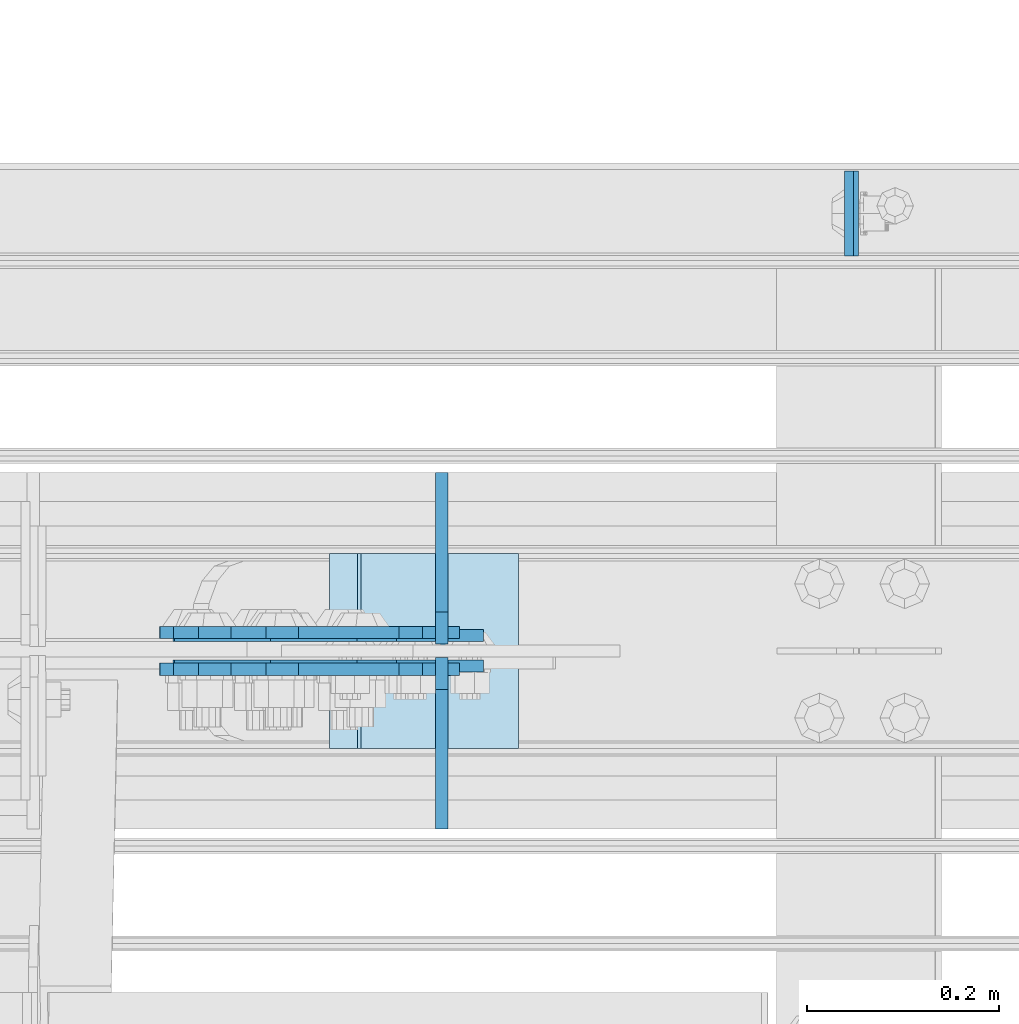
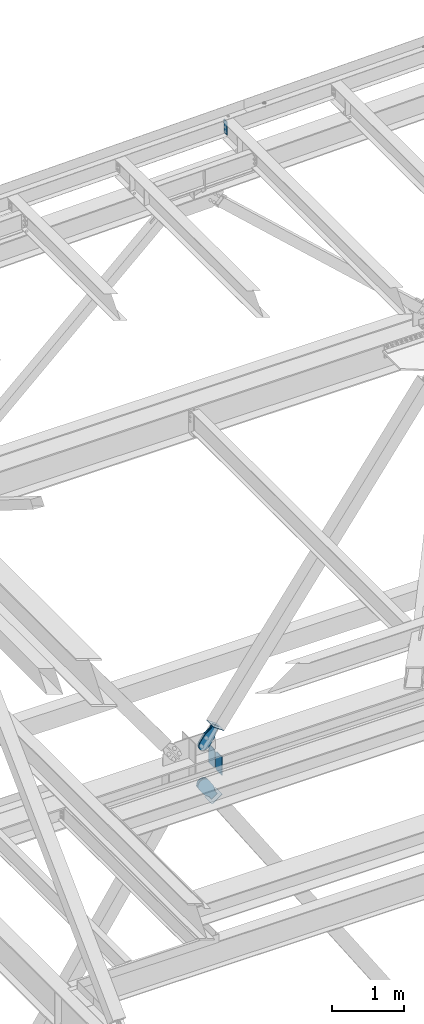
# One storey, part 3649 of 3843: 9 plates, 8 elements without a shape of their own.
"""IFC2X3 building model written with IfcOpenShell, lengths in millimetres."""

from ifc_helpers import new_model, si_unit, frame, origin_with_axes, place, context, subcontext, project, spatial, faceted_brep, material, type_object, element, aggregate, save


model = new_model("IFC2X3")

# Units and contexts
model_context = context("Model", 3, precision=1e-05, world=origin_with_axes())
body_context = subcontext(model_context, "Body", "Model", "MODEL_VIEW")
ifc_project = project(units=[si_unit("LENGTHUNIT", "METRE", prefix="MILLI"), si_unit("AREAUNIT", "SQUARE_METRE"), si_unit("VOLUMEUNIT", "CUBIC_METRE"), si_unit("MASSUNIT", "GRAM", prefix="KILO"), si_unit("TIMEUNIT", "SECOND"), si_unit("PLANEANGLEUNIT", "RADIAN"), si_unit("SOLIDANGLEUNIT", "STERADIAN"), si_unit("THERMODYNAMICTEMPERATUREUNIT", "DEGREE_CELSIUS"), si_unit("LUMINOUSINTENSITYUNIT", "LUMEN")], contexts=[model_context])

# Site, building, storey
site_placement = place(None, origin_with_axes())
site = spatial("IfcSite", under=ifc_project, at=site_placement, CompositionType="ELEMENT")
building_placement = place(site_placement, origin_with_axes())
building = spatial("IfcBuilding", under=site, at=building_placement, Name="Undefined", CompositionType="ELEMENT")
storey_placement = place(building_placement, origin_with_axes())
storey = spatial("IfcBuildingStorey", under=building, at=storey_placement, Name="Undefined", CompositionType="ELEMENT", Elevation=0.0)

# Assembly, plate
assembly_1_placement = place(storey_placement, origin_with_axes())
assembly_1 = element("IfcElementAssembly", 1, at=assembly_1_placement, inside=storey, Name="CHANNEL", AssemblyPlace="NOTDEFINED", PredefinedType="RIGID_FRAME")
ifc_material_1 = material(Name="STEEL/A572-50")
plate_type_1 = type_object("IfcPlateType", PredefinedType="NOTDEFINED")
plate_1_placement = place(assembly_1_placement, frame((82180.6886955897, 105059.162500026, 46656.3368329081), z_axis=(0.0, -1.0, 0.0), x_axis=(0.0211520550054438, 0.0, -0.999776270257025)))
plate_1 = element("IfcPlate", 2, at=plate_1_placement, type_object=plate_type_1, material=ifc_material_1, Name="PLATE", context=body_context, shape_type="Brep", body=[
    faceted_brep([(0.0, -4.76249999999709, 0.0), (0.0, -4.76249999999709, 88.9000015258789), (0.0, 4.76249999999709, 88.9000015258789), (0.0, 4.76249999999709, 0.0), (228.600006102781, -4.7625000004191, 88.9000015257589), (228.600006102781, 4.76249999954598, 88.9000015257443), (228.600006103079, -4.7625000004482, 7.27595761418343e-12), (228.600006103079, 4.76249999954598, -7.27595761418343e-12)], [[[0, 1, 2, 3]], [[1, 4, 5, 2]], [[4, 6, 7, 5]], [[6, 0, 3, 7]], [[5, 7, 3, 2]], [[6, 4, 1, 0]]]),
])
aggregate(assembly_1, [plate_1])

# Assembly, plates
assembly_2_placement = place(storey_placement, origin_with_axes())
assembly_2 = element("IfcElementAssembly", 3, at=assembly_2_placement, inside=storey, Name="BEAM", AssemblyPlace="NOTDEFINED", PredefinedType="RIGID_FRAME")
plate_type_2 = type_object("IfcPlateType", PredefinedType="NOTDEFINED")
plate_2_placement = place(assembly_2_placement, frame((81756.2703202162, 104566.24375, 36093.4), z_axis=(0.0, 1.0, 0.0), x_axis=(0.0, 0.0, 1.0)))
plate_2 = element("IfcPlate", 4, at=plate_2_placement, type_object=plate_type_2, material=ifc_material_1, Name="CB_BEAM", context=body_context, shape_type="Brep", body=[
    faceted_brep([(0.0, -6.34999999999854, 33.3375015258789), (0.0, -6.34999999999854, 178.59375), (0.0, 6.34999999999854, 178.59375), (0.0, 6.34999999999854, 33.3375015258789), (317.499999999985, -6.34999999999854, 178.59375), (317.499999999985, 6.34999999999854, 178.59375), (317.499999999985, -6.34999999999854, 33.3375015258789), (317.499999999985, 6.34999999999854, 33.3375015258789), (284.162498474107, -6.34999999999854, 0.0), (284.162498474107, 6.34999999999854, 0.0), (33.3375015258789, -6.34999999999854, 0.0), (33.3375015258789, 6.34999999999854, 0.0)], [[[0, 1, 2, 3]], [[1, 4, 5, 2]], [[4, 6, 7, 5]], [[6, 8, 9, 7]], [[8, 10, 11, 9]], [[10, 0, 3, 11]], [[5, 7, 9, 11, 3, 2]], [[10, 8, 6, 4, 1, 0]]]),
])
plate_3_placement = place(assembly_2_placement, frame((81756.2703202162, 104551.95625, 36093.4), z_axis=(0.0, -1.0, 0.0), x_axis=(0.0, 0.0, 1.0)))
plate_3 = element("IfcPlate", 5, at=plate_3_placement, type_object=plate_type_2, material=ifc_material_1, Name="CB_BEAM", context=body_context, shape_type="Brep", body=[
    faceted_brep([(0.0, -6.34999999999854, 33.3375015258789), (0.0, -6.34999999999854, 178.59375), (0.0, 6.34999999999854, 178.59375), (0.0, 6.34999999999854, 33.3375015258789), (317.499999999985, -6.34999999999854, 178.59375), (317.499999999985, 6.34999999999854, 178.59375), (317.499999999985, -6.34999999999854, 33.3375015258789), (317.499999999985, 6.34999999999854, 33.3375015258789), (284.162498474107, -6.34999999999854, 0.0), (284.162498474107, 6.34999999999854, 0.0), (33.3375015258789, -6.34999999999854, 0.0), (33.3375015258789, 6.34999999999854, 0.0)], [[[0, 1, 2, 3]], [[1, 4, 5, 2]], [[4, 6, 7, 5]], [[6, 8, 9, 7]], [[8, 10, 11, 9]], [[10, 0, 3, 11]], [[5, 7, 9, 11, 3, 2]], [[10, 8, 6, 4, 1, 0]]]),
])
aggregate(assembly_2, [plate_2, plate_3])

# Assembly, plate
assembly_3_placement = place(storey_placement, origin_with_axes())
assembly_3 = element("IfcElementAssembly", 6, at=assembly_3_placement, inside=storey, Name="Plate", AssemblyPlace="NOTDEFINED", PredefinedType="RIGID_FRAME")
ifc_material_2 = material(Name="STEEL/A36")
plate_type_3 = type_object("IfcPlateType", PredefinedType="NOTDEFINED")
plate_4_placement = place(assembly_3_placement, frame((81834.6793505776, 104457.5, 36773.0205801808), z_axis=(-0.809109618324204, 0.0, 0.58765774523549), x_axis=(0.0, 1.0, 0.0)))
plate_4 = element("IfcPlate", 7, at=plate_4_placement, type_object=plate_type_3, material=ifc_material_2, Name="Plate", context=body_context, shape_type="Brep", body=[
    faceted_brep([(0.0, -3.17499999999927, 0.0), (0.0, -3.17500000043947, 203.200000001736), (0.0, 3.1749999995518, 203.200000001743), (0.0, 3.17499999999927, 0.0), (203.200000000012, -3.17500000043947, 203.200000001736), (203.200000000012, 3.1749999995518, 203.200000001743), (203.199996948242, -3.17499999999927, 0.0), (203.199996948242, 3.17499999999927, 0.0)], [[[0, 1, 2, 3]], [[1, 4, 5, 2]], [[4, 6, 7, 5]], [[6, 0, 3, 7]], [[5, 7, 3, 2]], [[6, 4, 1, 0]]]),
])
aggregate(assembly_3, [plate_4])

assembly_4_placement = place(storey_placement, origin_with_axes())
assembly_4 = element("IfcElementAssembly", 8, at=assembly_4_placement, inside=storey, Name="Plate", AssemblyPlace="NOTDEFINED", PredefinedType="RIGID_FRAME")
plate_5_placement = place(assembly_4_placement, frame((81641.2596382379, 104660.7, 35595.7440063766), z_axis=(0.835270498690033, 0.0, 0.549839243795951), x_axis=(0.0, -1.0, 0.0)))
plate_5 = element("IfcPlate", 9, at=plate_5_placement, type_object=plate_type_3, material=ifc_material_2, Name="Plate", context=body_context, shape_type="Brep", body=[
    faceted_brep([(0.0, -3.17499999999927, 0.0), (0.0, -3.17500000043947, 203.200000001736), (0.0, 3.1749999995518, 203.200000001743), (0.0, 3.17499999999927, 0.0), (203.200000000012, -3.17500000043947, 203.200000001736), (203.200000000012, 3.1749999995518, 203.200000001743), (203.199996948242, -3.17499999999927, 0.0), (203.199996948242, 3.17499999999927, 0.0)], [[[0, 1, 2, 3]], [[1, 4, 5, 2]], [[4, 6, 7, 5]], [[6, 0, 3, 7]], [[5, 7, 3, 2]], [[6, 4, 1, 0]]]),
])
aggregate(assembly_4, [plate_5])

assembly_5_placement = place(storey_placement, origin_with_axes())
assembly_5 = element("IfcElementAssembly", 10, at=assembly_5_placement, inside=storey, AssemblyPlace="NOTDEFINED", PredefinedType="RIGID_FRAME")
plate_type_4 = type_object("IfcPlateType", PredefinedType="NOTDEFINED")
plate_6_placement = place(assembly_5_placement, frame((81758.6766864523, 104574.975, 36745.8160515626), z_axis=(-0.809109618324204, 0.0, 0.58765774523549), x_axis=(0.587657745235489, 0.0, 0.809109618324206)))
plate_6 = element("IfcPlate", 11, at=plate_6_placement, type_object=plate_type_4, material=ifc_material_2, context=body_context, shape_type="Brep", body=[
    faceted_brep([(0.0, -6.3499999046162, 0.0), (-101.600000000049, -6.35000000000582, -37.5700346004523), (-101.600000000049, 6.35000000000582, -37.5700346004523), (7.27595761418343e-12, 6.3499999046162, 0.0), (-245.369242325265, -6.35000000000582, -37.5700346003141), (-245.369242325265, 6.35000000000582, -37.5700346003141), (-281.212328726207, -6.35000000000582, -30.4404014297979), (-281.212328726207, 6.35000000000582, -30.4404014297979), (-311.59863014071, -6.35000000000582, -10.1369239383566), (-311.59863014071, 6.35000000000582, -10.1369239383566), (-331.902107630653, -6.35000000000582, 20.2493774772229), (-331.902107630653, 6.35000000000582, 20.2493774772229), (-339.031740799503, -6.35000000000582, 56.0924669294036), (-339.031740799503, 6.35000000000582, 56.0924669294036), (-331.902107628353, -6.35000000000582, 91.9355533280759), (-331.902107628353, 6.35000000000582, 91.9355533280759), (-311.598630138033, -6.35000000000582, 122.321854740563), (-311.598630138033, 6.35000000000582, 122.321854740563), (-281.212328724767, -6.35000000000582, 142.625332229603), (-281.212328724767, 6.35000000000582, 142.625332229603), (-245.369240796863, -6.35000000000582, 149.754965399145), (-245.369240796863, 6.35000000000582, 149.754965399145), (-101.599999991755, -6.35000000000582, 149.754965398992), (-101.599999991755, 6.35000000000582, 149.754965398992), (4.9622030928731e-09, -6.35000000000582, 112.184930798256), (4.9622030928731e-09, 6.35000000000582, 112.184930798256), (69.8500000038475, -6.35000000000582, 112.184930798168), (69.8500000038475, 6.35000000000582, 112.184930798168), (69.8499999985434, -6.35000000000582, -8.73114913702011e-11), (69.8499999985434, 6.35000000000582, -8.73114913702011e-11)], [[[0, 1, 2, 3]], [[1, 4, 5, 2]], [[4, 6, 7, 5]], [[6, 8, 9, 7]], [[8, 10, 11, 9]], [[10, 12, 13, 11]], [[12, 14, 15, 13]], [[14, 16, 17, 15]], [[16, 18, 19, 17]], [[18, 20, 21, 19]], [[20, 22, 23, 21]], [[22, 24, 25, 23]], [[24, 26, 27, 25]], [[26, 28, 29, 27]], [[28, 0, 3, 29]], [[5, 7, 9, 11, 13, 15, 17, 19, 21, 23, 25, 27, 29, 3, 2]], [[28, 26, 24, 22, 20, 18, 16, 14, 12, 10, 8, 6, 4, 1, 0]]]),
])
aggregate(assembly_5, [plate_6])

assembly_6_placement = place(storey_placement, origin_with_axes())
assembly_6 = element("IfcElementAssembly", 12, at=assembly_6_placement, inside=storey, AssemblyPlace="NOTDEFINED", PredefinedType="RIGID_FRAME")
plate_7_placement = place(assembly_6_placement, frame((81758.6766864523, 104543.225, 36745.8160515626), z_axis=(-0.809109618324204, 0.0, 0.58765774523549), x_axis=(0.587657745235489, 0.0, 0.809109618324206)))
plate_7 = element("IfcPlate", 13, at=plate_7_placement, type_object=plate_type_4, material=ifc_material_2, context=body_context, shape_type="Brep", body=[
    faceted_brep([(0.0, -6.3499999046162, 0.0), (-101.600000000049, -6.35000000000582, -37.5700346004523), (-101.600000000049, 6.35000000000582, -37.5700346004523), (7.27595761418343e-12, 6.3499999046162, 0.0), (-245.369242325265, -6.35000000000582, -37.5700346003141), (-245.369242325265, 6.35000000000582, -37.5700346003141), (-281.212328726207, -6.35000000000582, -30.4404014297979), (-281.212328726207, 6.35000000000582, -30.4404014297979), (-311.59863014071, -6.35000000000582, -10.1369239383566), (-311.59863014071, 6.35000000000582, -10.1369239383566), (-331.902107630653, -6.35000000000582, 20.2493774772229), (-331.902107630653, 6.35000000000582, 20.2493774772229), (-339.031740799503, -6.35000000000582, 56.0924669294036), (-339.031740799503, 6.35000000000582, 56.0924669294036), (-331.902107628353, -6.35000000000582, 91.9355533280759), (-331.902107628353, 6.35000000000582, 91.9355533280759), (-311.598630138033, -6.35000000000582, 122.321854740563), (-311.598630138033, 6.35000000000582, 122.321854740563), (-281.212328724767, -6.35000000000582, 142.625332229603), (-281.212328724767, 6.35000000000582, 142.625332229603), (-245.369240796863, -6.35000000000582, 149.754965399145), (-245.369240796863, 6.35000000000582, 149.754965399145), (-101.599999991755, -6.35000000000582, 149.754965398992), (-101.599999991755, 6.35000000000582, 149.754965398992), (4.9622030928731e-09, -6.35000000000582, 112.184930798256), (4.9622030928731e-09, 6.35000000000582, 112.184930798256), (69.8500000038475, -6.35000000000582, 112.184930798168), (69.8500000038475, 6.35000000000582, 112.184930798168), (69.8499999985434, -6.35000000000582, -8.73114913702011e-11), (69.8499999985434, 6.35000000000582, -8.73114913702011e-11)], [[[0, 1, 2, 3]], [[1, 4, 5, 2]], [[4, 6, 7, 5]], [[6, 8, 9, 7]], [[8, 10, 11, 9]], [[10, 12, 13, 11]], [[12, 14, 15, 13]], [[14, 16, 17, 15]], [[16, 18, 19, 17]], [[18, 20, 21, 19]], [[20, 22, 23, 21]], [[22, 24, 25, 23]], [[24, 26, 27, 25]], [[26, 28, 29, 27]], [[28, 0, 3, 29]], [[5, 7, 9, 11, 13, 15, 17, 19, 21, 23, 25, 27, 29, 3, 2]], [[28, 26, 24, 22, 20, 18, 16, 14, 12, 10, 8, 6, 4, 1, 0]]]),
])
aggregate(assembly_6, [plate_7])

assembly_7_placement = place(storey_placement, origin_with_axes())
assembly_7 = element("IfcElementAssembly", 14, at=assembly_7_placement, inside=storey, AssemblyPlace="NOTDEFINED", PredefinedType="RIGID_FRAME")
plate_8_placement = place(assembly_7_placement, frame((81736.314970746, 104578.15, 35738.1411727646), z_axis=(-0.835270498690038, 0.0, -0.549839243795943), x_axis=(0.549839243795943, 0.0, -0.835270498690039)))
plate_8 = element("IfcPlate", 15, at=plate_8_placement, type_object=plate_type_4, material=ifc_material_2, context=body_context, shape_type="Brep", body=[
    faceted_brep([(0.0, -6.3499999046162, 0.0), (-101.600000000049, -6.35000000000582, -37.5700346004523), (-101.600000000049, 6.35000000000582, -37.5700346004523), (7.27595761418343e-12, 6.3499999046162, 0.0), (-245.369242325265, -6.35000000000582, -37.5700346003141), (-245.369242325265, 6.35000000000582, -37.5700346003141), (-281.212328726207, -6.35000000000582, -30.4404014297979), (-281.212328726207, 6.35000000000582, -30.4404014297979), (-311.59863014071, -6.35000000000582, -10.1369239383566), (-311.59863014071, 6.35000000000582, -10.1369239383566), (-331.902107630653, -6.35000000000582, 20.2493774772229), (-331.902107630653, 6.35000000000582, 20.2493774772229), (-339.031740799503, -6.35000000000582, 56.0924669294036), (-339.031740799503, 6.35000000000582, 56.0924669294036), (-331.902107628353, -6.35000000000582, 91.9355533280759), (-331.902107628353, 6.35000000000582, 91.9355533280759), (-311.598630138033, -6.35000000000582, 122.321854740563), (-311.598630138033, 6.35000000000582, 122.321854740563), (-281.212328724767, -6.35000000000582, 142.625332229603), (-281.212328724767, 6.35000000000582, 142.625332229603), (-245.369240796863, -6.35000000000582, 149.754965399145), (-245.369240796863, 6.35000000000582, 149.754965399145), (-101.599999991755, -6.35000000000582, 149.754965398992), (-101.599999991755, 6.35000000000582, 149.754965398992), (4.9622030928731e-09, -6.35000000000582, 112.184930798256), (4.9622030928731e-09, 6.35000000000582, 112.184930798256), (69.8500000038475, -6.35000000000582, 112.184930798168), (69.8500000038475, 6.35000000000582, 112.184930798168), (69.8499999985434, -6.35000000000582, -8.73114913702011e-11), (69.8499999985434, 6.35000000000582, -8.73114913702011e-11)], [[[0, 1, 2, 3]], [[1, 4, 5, 2]], [[4, 6, 7, 5]], [[6, 8, 9, 7]], [[8, 10, 11, 9]], [[10, 12, 13, 11]], [[12, 14, 15, 13]], [[14, 16, 17, 15]], [[16, 18, 19, 17]], [[18, 20, 21, 19]], [[20, 22, 23, 21]], [[22, 24, 25, 23]], [[24, 26, 27, 25]], [[26, 28, 29, 27]], [[28, 0, 3, 29]], [[5, 7, 9, 11, 13, 15, 17, 19, 21, 23, 25, 27, 29, 3, 2]], [[28, 26, 24, 22, 20, 18, 16, 14, 12, 10, 8, 6, 4, 1, 0]]]),
])
aggregate(assembly_7, [plate_8])

assembly_8_placement = place(storey_placement, origin_with_axes())
assembly_8 = element("IfcElementAssembly", 16, at=assembly_8_placement, inside=storey, AssemblyPlace="NOTDEFINED", PredefinedType="RIGID_FRAME")
plate_9_placement = place(assembly_8_placement, frame((81736.314970746, 104540.05, 35738.1411727646), z_axis=(-0.835270498690038, 0.0, -0.549839243795943), x_axis=(0.549839243795943, 0.0, -0.835270498690039)))
plate_9 = element("IfcPlate", 17, at=plate_9_placement, type_object=plate_type_4, material=ifc_material_2, context=body_context, shape_type="Brep", body=[
    faceted_brep([(0.0, -6.3499999046162, 0.0), (-101.600000000049, -6.35000000000582, -37.5700346004523), (-101.600000000049, 6.35000000000582, -37.5700346004523), (7.27595761418343e-12, 6.3499999046162, 0.0), (-245.369242325265, -6.35000000000582, -37.5700346003141), (-245.369242325265, 6.35000000000582, -37.5700346003141), (-281.212328726207, -6.35000000000582, -30.4404014297979), (-281.212328726207, 6.35000000000582, -30.4404014297979), (-311.59863014071, -6.35000000000582, -10.1369239383566), (-311.59863014071, 6.35000000000582, -10.1369239383566), (-331.902107630653, -6.35000000000582, 20.2493774772229), (-331.902107630653, 6.35000000000582, 20.2493774772229), (-339.031740799503, -6.35000000000582, 56.0924669294036), (-339.031740799503, 6.35000000000582, 56.0924669294036), (-331.902107628353, -6.35000000000582, 91.9355533280759), (-331.902107628353, 6.35000000000582, 91.9355533280759), (-311.598630138033, -6.35000000000582, 122.321854740563), (-311.598630138033, 6.35000000000582, 122.321854740563), (-281.212328724767, -6.35000000000582, 142.625332229603), (-281.212328724767, 6.35000000000582, 142.625332229603), (-245.369240796863, -6.35000000000582, 149.754965399145), (-245.369240796863, 6.35000000000582, 149.754965399145), (-101.599999991755, -6.35000000000582, 149.754965398992), (-101.599999991755, 6.35000000000582, 149.754965398992), (4.9622030928731e-09, -6.35000000000582, 112.184930798256), (4.9622030928731e-09, 6.35000000000582, 112.184930798256), (69.8500000038475, -6.35000000000582, 112.184930798168), (69.8500000038475, 6.35000000000582, 112.184930798168), (69.8499999985434, -6.35000000000582, -8.73114913702011e-11), (69.8499999985434, 6.35000000000582, -8.73114913702011e-11)], [[[0, 1, 2, 3]], [[1, 4, 5, 2]], [[4, 6, 7, 5]], [[6, 8, 9, 7]], [[8, 10, 11, 9]], [[10, 12, 13, 11]], [[12, 14, 15, 13]], [[14, 16, 17, 15]], [[16, 18, 19, 17]], [[18, 20, 21, 19]], [[20, 22, 23, 21]], [[22, 24, 25, 23]], [[24, 26, 27, 25]], [[26, 28, 29, 27]], [[28, 0, 3, 29]], [[5, 7, 9, 11, 13, 15, 17, 19, 21, 23, 25, 27, 29, 3, 2]], [[28, 26, 24, 22, 20, 18, 16, 14, 12, 10, 8, 6, 4, 1, 0]]]),
])
aggregate(assembly_8, [plate_9])

save(model, "model.ifc")
